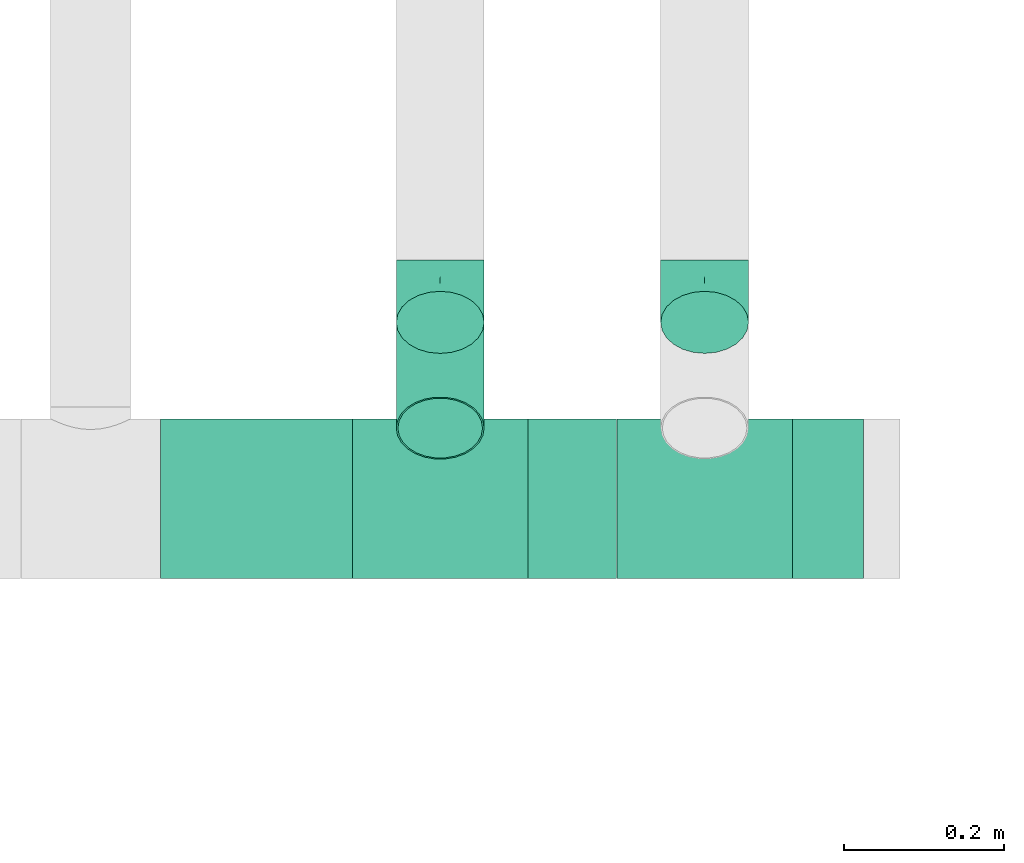
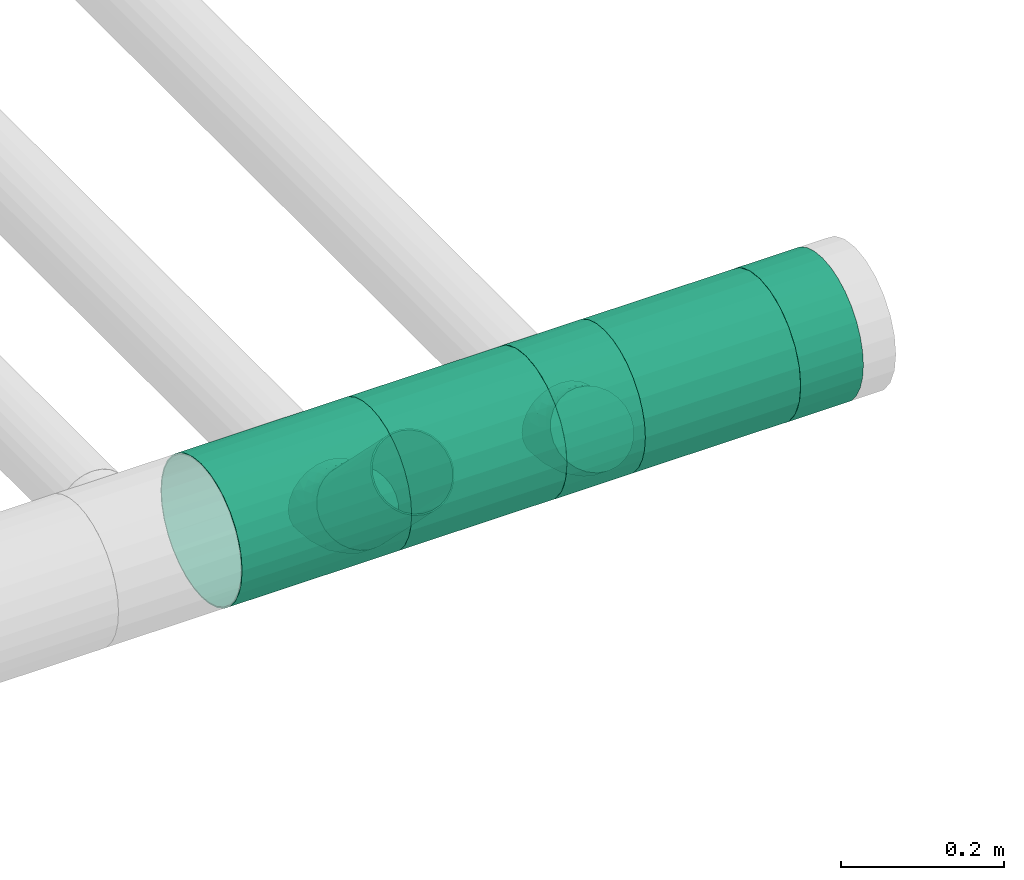
# One storey, part 86 of 91: 4 flow fittings, 4 flow segments.
"""IFC2X3 building model written with IfcOpenShell, lengths in millimetres."""

from ifc_helpers import new_model, entity, si_unit, converted_unit, derived_unit, direction, frame, origin_with_axes, origin_2d_with_axis, place, context, subcontext, project, spatial, hollow_circle, extrude, open_shell, surface_model, source, transform, mapped, material, layer, layer_set, layer_usage, type_object, element, save


model = new_model("IFC2X3")

# Units and contexts
model_context = context("Model", 3, precision=1e-05, world=origin_with_axes(), true_north=direction((0.0, 1.0)))
body_context = subcontext(model_context, "Body", "Model", "MODEL_VIEW")
ifc_project = project(units=[si_unit("AREAUNIT", "SQUARE_METRE"), si_unit("VOLUMEUNIT", "CUBIC_METRE", prefix="DECI"), si_unit("TIMEUNIT", "SECOND"), si_unit("THERMODYNAMICTEMPERATUREUNIT", "DEGREE_CELSIUS"), si_unit("PRESSUREUNIT", "PASCAL"), si_unit("MASSUNIT", "GRAM", prefix="KILO"), si_unit("LENGTHUNIT", "METRE", prefix="MILLI"), si_unit("POWERUNIT", "WATT"), si_unit("ELECTRICCURRENTUNIT", "AMPERE"), si_unit("ELECTRICVOLTAGEUNIT", "VOLT"), derived_unit("VOLUMETRICFLOWRATEUNIT", [(si_unit("VOLUMEUNIT", "CUBIC_METRE", prefix="DECI"), 1), (si_unit("TIMEUNIT", "SECOND"), -1)]), derived_unit("LINEARVELOCITYUNIT", [(si_unit("LENGTHUNIT", "METRE"), 1), (si_unit("TIMEUNIT", "SECOND"), -1)]), derived_unit("MASSDENSITYUNIT", [(si_unit("MASSUNIT", "GRAM", prefix="KILO"), 1), (si_unit("VOLUMEUNIT", "CUBIC_METRE"), -1)]), converted_unit("PLANEANGLEUNIT", "DEGREE", entity("IfcRatioMeasure", 0.01745), si_unit("PLANEANGLEUNIT", "RADIAN"), dimensions=[0, 0, 0, 0, 0, 0, 0])], contexts=[model_context])

# Site, building, storey
site_placement = place(None, origin_with_axes())
site = spatial("IfcSite", under=ifc_project, at=site_placement, CompositionType="ELEMENT")
building_placement = place(site_placement, origin_with_axes())
building = spatial("IfcBuilding", under=site, at=building_placement, Name="mc-building", CompositionType="ELEMENT")
storey_placement = place(building_placement, frame((0.0, 0.0, 8700.0), z_axis=(0.0, 0.0, 1.0), x_axis=(1.0, 0.0, 0.0)))
storey = spatial("IfcBuildingStorey", under=building, at=storey_placement, CompositionType="ELEMENT", Elevation=8700.0)

# Flow fittings
duct_fitting_type_1 = type_object("IfcDuctFittingType", Name="BU", PredefinedType="BEND")
shared_shape_1 = source(origin_with_axes(), body_context, "Body", "SurfaceModel", [
    surface_model("IfcShellBasedSurfaceModel", [(-45.56349, 0.0, -55.0), (-45.56349, -14.23505, -53.12592), (-45.56349, 14.23505, -53.12592), (-45.56349, 53.12592, 14.23505), (-45.56349, 27.5, -47.63139), (-45.56349, 38.89087, -38.89087), (-45.56349, 47.63139, -27.5), (-45.56349, -55.0, 0.0), (-45.56349, -53.12592, 14.23505), (-45.56349, -38.89087, -38.89087), (-45.56349, -27.5, -47.63139), (-45.56349, -53.12592, -14.23505), (-45.56349, -47.63139, -27.5), (-45.56349, 53.12592, -14.23505), (-45.56349, 47.63139, 27.5), (-45.56349, 38.89087, 38.89087), (-45.56349, -14.23505, 53.12592), (-45.56349, 27.5, 47.63139), (-45.56349, 14.23505, 53.12592), (-45.56349, -47.63139, 27.5), (-45.56349, -38.89087, 38.89087), (-45.56349, -27.5, 47.63139), (-45.56349, 0.0, 55.0), (-45.56349, 55.0, 0.0), (22.15256, 42.28395, -53.12592), (-6.67262, 71.10913, 0.0), (32.21826, 32.21826, -55.0), (12.77282, 51.66369, -47.63139), (-1.46223, 65.89874, -27.5), (4.71825, 59.71825, -38.89087), (59.71825, 4.71825, -38.89087), (69.78395, -5.34744, 14.23505), (51.66369, 12.77282, -47.63139), (42.28395, 22.15256, -53.12592), (65.89874, -1.46223, -27.5), (69.78395, -5.34744, -14.23505), (71.10913, -6.67262, 0.0), (-5.34744, 69.78395, -14.23505), (-5.34744, 69.78395, 14.23505), (-1.46223, 65.89874, 27.5), (4.71825, 59.71825, 38.89087), (32.21826, 32.21826, 55.0), (12.77282, 51.66369, 47.63139), (22.15256, 42.28395, 53.12592), (59.71825, 4.71825, 38.89087), (65.89874, -1.46223, 27.5), (42.28395, 22.15256, 53.12592), (51.66369, 12.77282, 47.63139), (-20.16649, 48.68621, 33.48188), (-26.97111, 35.77503, 43.63444), (-7.30443, 43.73336, 43.63444), (-17.0934, 3.74816, 55.0), (-18.00408, 15.44793, 53.78143), (-30.11707, 22.39897, 50.81337), (-7.49776, 55.63651, 33.48188), (-15.97018, 58.74288, 21.04759), (-31.18231, 52.58712, 21.04759), (-18.35174, 61.03934, 10.51509), (-28.67677, 56.60048, 10.47121), (-34.03924, 44.64267, 33.48188), (-11.52288, 27.81868, 50.81338), (1.19951, 23.16465, 53.81115), (-33.77926, 57.34403, 0.0), (5.4586, 37.12132, 50.81809), (-24.5159, 59.18663, 0.0), (-16.66281, 64.4339, 0.0), (9.43651, 14.73721, 55.0), (-6.22531, 44.36822, -43.63444), (5.4586, 37.12132, -50.81809), (-34.03924, 44.64267, -33.48188), (9.43651, 14.73721, -55.0), (-17.0934, 3.74816, -55.0), (1.19951, 23.16465, -53.81115), (-11.52288, 27.81868, -50.81338), (-30.11707, 22.39897, -50.81337), (-25.75914, 36.08917, -43.63444), (-30.24487, 52.83011, -21.04759), (-20.16649, 48.68621, -33.48188), (-7.49776, 55.63651, -33.48188), (-18.00408, 15.44793, -53.78143), (-28.68366, 56.62226, -10.35271), (-14.15883, 63.53074, -10.87592), (-15.13548, 59.23394, -21.04759), (3.19797, -7.72059, -52.16847), (3.1272, -18.04126, -47.9241), (13.63233, -32.91136, -32.06475), (45.23618, -22.99734, -20.4997), (16.67434, -40.25541, -15.9539), (-17.3935, -51.68264, -9.80849), (-2.85835, -49.37776, 0.0), (48.84421, -24.24609, -9.80849), (-16.38424, -42.76862, -30.85433), (-6.97383, -29.41689, -42.70541), (41.82739, -18.65658, -30.85433), (-15.72523, -48.24839, -20.4997), (29.28945, -13.63928, -42.80781), (26.81493, -3.56603, -49.15704), (36.93651, -32.89419, 0.0), (-15.72523, -48.24839, 20.4997), (-17.3935, -51.68264, 9.80849), (-16.38424, -42.76862, 30.85433), (16.67434, -40.25541, 15.9539), (3.19797, -7.72059, 52.16847), (10.54583, -14.96836, 47.9241), (13.63233, -32.91136, 32.06475), (45.23618, -22.99734, 20.4997), (41.82739, -18.65658, 30.85433), (-11.06635, -30.3552, 42.80781), (25.73213, -15.86964, 42.70541), (-16.43945, -21.48258, 49.15704), (48.84421, -24.24609, 9.80849)], [open_shell([[[0, 1, 2]], [[2, 3, 4]], [[5, 3, 6]], [[4, 3, 5]], [[2, 7, 8]], [[9, 7, 10]], [[1, 10, 7]], [[11, 7, 12]], [[9, 12, 7]], [[7, 2, 1]], [[13, 6, 3]], [[14, 3, 2]], [[15, 14, 2]], [[16, 17, 2]], [[2, 17, 15]], [[16, 18, 17]], [[19, 20, 2]], [[19, 2, 8]], [[20, 21, 2]], [[2, 21, 16]], [[16, 22, 18]], [[23, 13, 3]], [[24, 25, 26]], [[27, 25, 24]], [[28, 25, 29]], [[29, 25, 27]], [[30, 26, 31]], [[26, 30, 32]], [[32, 33, 26]], [[34, 31, 35]], [[31, 34, 30]], [[35, 31, 36]], [[37, 25, 28]], [[26, 38, 39]], [[26, 39, 40]], [[41, 40, 42]], [[26, 40, 41]], [[42, 43, 41]], [[26, 44, 45]], [[31, 26, 45]], [[46, 47, 26]], [[47, 44, 26]], [[46, 26, 41]], [[26, 25, 38]], [[48, 49, 50]], [[22, 51, 52]], [[17, 49, 15]], [[53, 17, 18]], [[49, 17, 53]], [[54, 50, 40]], [[48, 55, 56]], [[55, 57, 58]], [[59, 14, 15]], [[60, 53, 52]], [[50, 49, 60]], [[58, 3, 56]], [[52, 51, 61]], [[62, 23, 3]], [[63, 50, 60]], [[50, 42, 40]], [[3, 58, 62]], [[43, 61, 41]], [[62, 58, 64]], [[48, 59, 49]], [[14, 56, 3]], [[40, 39, 54]], [[57, 64, 58]], [[39, 38, 55]], [[63, 60, 61]], [[54, 55, 48]], [[65, 57, 38]], [[56, 14, 59]], [[38, 25, 65]], [[60, 52, 61]], [[49, 59, 15]], [[55, 58, 56]], [[56, 59, 48]], [[55, 54, 39]], [[50, 54, 48]], [[18, 22, 52]], [[49, 53, 60]], [[18, 52, 53]], [[61, 51, 66]], [[41, 61, 66]], [[63, 61, 43]], [[43, 42, 63]], [[50, 63, 42]], [[38, 57, 55]], [[64, 57, 65]], [[67, 27, 68]], [[69, 5, 6]], [[70, 71, 72]], [[73, 74, 75]], [[76, 77, 69]], [[29, 78, 28]], [[2, 79, 0]], [[13, 23, 62]], [[2, 74, 79]], [[5, 75, 4]], [[77, 78, 67]], [[13, 62, 80]], [[64, 80, 62]], [[81, 80, 64]], [[67, 73, 75]], [[82, 77, 76]], [[81, 64, 65]], [[76, 69, 6]], [[82, 76, 80]], [[24, 72, 68]], [[74, 2, 4]], [[27, 67, 29]], [[26, 70, 72]], [[69, 75, 5]], [[82, 28, 78]], [[72, 71, 79]], [[6, 13, 76]], [[77, 67, 75]], [[13, 80, 76]], [[82, 37, 28]], [[81, 25, 37]], [[82, 81, 37]], [[75, 69, 77]], [[67, 78, 29]], [[82, 78, 77]], [[75, 74, 4]], [[79, 74, 73]], [[79, 73, 72]], [[79, 71, 0]], [[68, 72, 73]], [[26, 72, 24]], [[67, 68, 73]], [[27, 24, 68]], [[80, 81, 82]], [[25, 81, 65]], [[1, 83, 84]], [[85, 86, 87]], [[0, 71, 1]], [[88, 87, 89]], [[90, 86, 35]], [[91, 92, 85]], [[11, 88, 7]], [[30, 34, 93]], [[11, 12, 94]], [[92, 91, 9]], [[85, 94, 91]], [[94, 85, 87]], [[95, 93, 85]], [[85, 92, 95]], [[83, 71, 70]], [[12, 9, 91]], [[70, 26, 33]], [[96, 84, 83]], [[1, 71, 83]], [[95, 96, 32]], [[95, 30, 93]], [[95, 32, 30]], [[97, 89, 87]], [[34, 86, 93]], [[36, 97, 90]], [[94, 88, 11]], [[34, 35, 86]], [[90, 87, 86]], [[93, 86, 85]], [[32, 96, 33]], [[84, 10, 1]], [[33, 83, 70]], [[94, 12, 91]], [[10, 92, 9]], [[87, 88, 94]], [[7, 88, 89]], [[36, 90, 35]], [[87, 90, 97]], [[84, 95, 92]], [[33, 96, 83]], [[95, 84, 96]], [[10, 84, 92]], [[8, 98, 19]], [[7, 89, 99]], [[19, 98, 100]], [[101, 98, 99]], [[46, 102, 103]], [[104, 105, 106]], [[100, 98, 104]], [[107, 104, 108]], [[16, 51, 22]], [[51, 16, 102]], [[107, 20, 100]], [[107, 109, 21]], [[21, 20, 107]], [[103, 47, 46]], [[101, 89, 97]], [[105, 110, 31]], [[44, 47, 108]], [[105, 104, 101]], [[107, 100, 104]], [[31, 110, 36]], [[109, 16, 21]], [[108, 106, 44]], [[105, 45, 106]], [[41, 66, 46]], [[102, 66, 51]], [[46, 66, 102]], [[104, 98, 101]], [[99, 98, 8]], [[106, 108, 104]], [[110, 101, 97]], [[45, 44, 106]], [[105, 31, 45]], [[20, 19, 100]], [[109, 103, 102]], [[101, 110, 105]], [[36, 110, 97]], [[7, 99, 8]], [[101, 99, 89]], [[103, 107, 108]], [[16, 109, 102]], [[107, 103, 109]], [[47, 103, 108]]])]),
])
for number, where, z_axis, x_axis, name in (
    (1, (36722.77222, 10333.96985, 415.0), (-1.0, 0.0, 0.0), (0.0, -1.0, 0.0), "BU"),
    (2, (36391.76813, 10333.96985, 415.0), (-1.0, 0.0, 0.0), (0.0, -1.0, 0.0), "BU"),
):
    element("IfcFlowFitting", number, at=place(storey_placement, frame(where, z_axis=z_axis, x_axis=x_axis)), inside=storey, type_object=duct_fitting_type_1, Name=name, context=body_context, shape_type="MappedRepresentation", body=[
        mapped(shared_shape_1, transform((0.0, 0.0, 0.0), scale=1.0)),
    ])

# Flow segments
ifc_material = material(Name="FZ1")
ifc_layer = layer(ifc_material, 0.0)
ifc_layer_set = layer_set([ifc_layer], Name="FZ1")
ifc_layer_usage = layer_usage(ifc_layer_set, "AXIS1", "POSITIVE", 0.0)
duct_segment_type_1 = type_object("IfcDuctSegmentType", PredefinedType="RIGIDSEGMENT")
shared_shape_2 = source(origin_with_axes(), body_context, "Body", "SweptSolid", [
    extrude(hollow_circle(Radius=55.0, WallThickness=2.0, at=origin_2d_with_axis()), frame((0.0, 0.0, 0.0), z_axis=(1.0, 0.0, 0.0), x_axis=(0.0, 1.0, 0.0)), (0.0, 0.0, 1.0), 187.2),
])
flow_segment_1_placement = place(storey_placement, frame((36391.76813, 10169.3582, 579.61165), z_axis=(0.0, -0.707107, -0.707107), x_axis=(0.0, 0.707107, -0.707107)))
element("IfcFlowSegment", 3, at=flow_segment_1_placement, inside=storey, type_object=duct_segment_type_1, material=ifc_layer_usage, context=body_context, shape_type="MappedRepresentation", body=[
    mapped(shared_shape_2, transform((0.0, 0.0, 0.0), scale=1.0)),
])
duct_segment_type_2 = type_object("IfcDuctSegmentType", Name="Safe", PredefinedType="RIGIDSEGMENT")
shared_shape_3 = source(origin_with_axes(), body_context, "Body", "SweptSolid", [
    extrude(hollow_circle(Radius=100.0, WallThickness=2.0, at=origin_2d_with_axis()), frame((0.0, 0.0, 0.0), z_axis=(1.0, 0.0, 0.0), x_axis=(0.0, 1.0, 0.0)), (0.0, 0.0, 1.0), 88.8),
])
flow_segment_2_placement = place(storey_placement, frame((36832.77222, 10080.96985, 668.0), z_axis=(0.0, 0.0, 1.0), x_axis=(1.0, 0.0, 0.0)))
element("IfcFlowSegment", 4, at=flow_segment_2_placement, inside=storey, type_object=duct_segment_type_2, material=ifc_layer_usage, Name="Safe", context=body_context, shape_type="MappedRepresentation", body=[
    mapped(shared_shape_3, transform((0.0, 0.0, 0.0), scale=1.0)),
])

# Flow fittings
duct_fitting_type_2 = type_object("IfcDuctFittingType", PredefinedType="JUNCTION")
shared_shape_4 = source(origin_with_axes(), body_context, "Body", "SurfaceModel", [
    surface_model("IfcShellBasedSurfaceModel", [(0.0, -125.0, -55.0), (14.23505, -125.0, -53.12592), (-14.23505, -125.0, -53.12592), (-53.12592, -125.0, 14.23505), (-27.5, -125.0, -47.63139), (-47.63139, -125.0, -27.5), (-38.89087, -125.0, -38.89087), (55.0, -125.0, 0.0), (53.12592, -125.0, 14.23505), (38.89087, -125.0, -38.89087), (27.5, -125.0, -47.63139), (53.12592, -125.0, -14.23505), (47.63139, -125.0, -27.5), (-53.12592, -125.0, -14.23505), (-47.63139, -125.0, 27.5), (-38.89087, -125.0, 38.89087), (14.23505, -125.0, 53.12592), (-27.5, -125.0, 47.63139), (-14.23505, -125.0, 53.12592), (47.63139, -125.0, 27.5), (38.89087, -125.0, 38.89087), (27.5, -125.0, 47.63139), (0.0, -125.0, 55.0), (-55.0, -125.0, 0.0), (0.0, -83.51647, 55.0), (-12.46155, -84.44105, 53.56967), (-24.08744, -86.92068, 49.44487), (-34.33571, -90.29918, 42.96579), (-42.88021, -93.88137, 34.44253), (-49.41352, -97.03966, 24.15169), (-53.56772, -99.21945, 12.46996), (-55.0, -100.0, 0.0), (-49.4132, -97.0395, -24.15234), (-42.88214, -93.88226, -34.44012), (-53.56653, -99.21882, -12.47503), (-34.33656, -90.29949, -42.96511), (-24.08533, -86.92009, -49.4459), (-12.45457, -84.44001, -53.57129), (0.0, -83.51647, -55.0), (12.46155, -84.44105, -53.56967), (24.08744, -86.92068, -49.44487), (34.33571, -90.29918, -42.96579), (42.88021, -93.88137, -34.44253), (49.41352, -97.03966, -24.15169), (53.56772, -99.21945, -12.46996), (55.0, -100.0, 0.0), (49.41352, -97.03966, 24.15169), (42.88021, -93.88137, 34.44253), (53.56772, -99.21945, 12.46996), (34.33571, -90.29918, 42.96579), (24.08744, -86.92068, 49.44487), (12.46155, -84.44105, 53.56967), (-110.0, 0.0, -100.0), (-110.0, -25.8819, -96.59259), (-110.0, 25.8819, -96.59259), (-110.0, 96.59259, 25.8819), (-110.0, 50.0, -86.60254), (-110.0, 86.60254, -50.0), (-110.0, 70.71068, -70.71068), (-110.0, -100.0, 0.0), (-110.0, -96.59259, 25.8819), (-110.0, -70.71068, -70.71068), (-110.0, -50.0, -86.60254), (-110.0, -96.59259, -25.8819), (-110.0, -86.60254, -50.0), (-110.0, 96.59259, -25.8819), (-110.0, 86.60254, 50.0), (-110.0, 70.71068, 70.71068), (-110.0, 50.0, 86.60254), (-110.0, 25.8819, 96.59259), (-110.0, 0.0, 100.0), (-110.0, -86.60254, 50.0), (-110.0, -70.71068, 70.71068), (-110.0, -25.8819, 96.59259), (-110.0, -50.0, 86.60254), (-110.0, 100.0, 0.0), (110.0, 25.8819, -96.59259), (110.0, 100.0, 0.0), (110.0, 0.0, -100.0), (110.0, 50.0, -86.60254), (110.0, 86.60254, -50.0), (110.0, 70.71068, -70.71068), (110.0, -70.71068, -70.71068), (110.0, -96.59259, 25.8819), (110.0, -50.0, -86.60254), (110.0, -25.8819, -96.59259), (110.0, -86.60254, -50.0), (110.0, -96.59259, -25.8819), (110.0, -100.0, 0.0), (110.0, 96.59259, -25.8819), (110.0, 86.60254, 50.0), (110.0, 96.59259, 25.8819), (110.0, 50.0, 86.60254), (110.0, 25.8819, 96.59259), (110.0, 70.71068, 70.71068), (110.0, -25.8819, 96.59259), (110.0, -86.60254, 50.0), (110.0, -70.71068, 70.71068), (110.0, -50.0, 86.60254), (110.0, 0.0, 100.0), (-110.0, -98.29629, -12.94095), (110.0, -91.59756, -37.94095), (-110.0, -91.59756, -37.94095), (110.0, -98.29629, -12.94095), (110.0, -98.29629, 12.94095), (110.0, -91.59756, 37.94095), (-110.0, -98.29629, 12.94095), (-110.0, -91.59756, 37.94095)], [open_shell([[[0, 1, 2]], [[2, 3, 4]], [[5, 6, 3]], [[6, 4, 3]], [[2, 7, 8]], [[9, 7, 10]], [[1, 10, 7]], [[11, 7, 12]], [[9, 12, 7]], [[7, 2, 1]], [[5, 3, 13]], [[2, 14, 3]], [[2, 15, 14]], [[2, 16, 17]], [[17, 15, 2]], [[16, 18, 17]], [[2, 8, 19]], [[2, 19, 20]], [[2, 20, 21]], [[16, 2, 21]], [[16, 22, 18]], [[23, 13, 3]], [[22, 24, 25]], [[18, 25, 26]], [[22, 25, 18]], [[17, 27, 15]], [[17, 18, 26]], [[27, 17, 26]], [[28, 29, 14]], [[30, 31, 23]], [[29, 30, 3]], [[15, 28, 14]], [[23, 3, 30]], [[29, 3, 14]], [[28, 15, 27]], [[32, 33, 5]], [[34, 32, 13]], [[31, 34, 23]], [[23, 34, 13]], [[32, 5, 13]], [[33, 6, 5]], [[4, 35, 36]], [[36, 37, 2]], [[38, 0, 37]], [[6, 35, 4]], [[4, 36, 2]], [[37, 0, 2]], [[35, 6, 33]], [[0, 38, 39]], [[1, 39, 40]], [[0, 39, 1]], [[10, 41, 9]], [[10, 1, 40]], [[41, 10, 40]], [[42, 43, 12]], [[44, 45, 7]], [[43, 44, 11]], [[12, 9, 42]], [[11, 12, 43]], [[44, 7, 11]], [[42, 9, 41]], [[46, 47, 19]], [[48, 46, 8]], [[45, 48, 7]], [[7, 48, 8]], [[46, 19, 8]], [[47, 20, 19]], [[21, 49, 50]], [[50, 51, 16]], [[24, 22, 51]], [[21, 20, 49]], [[16, 21, 50]], [[51, 22, 16]], [[49, 20, 47]], [[52, 53, 54]], [[54, 55, 56]], [[57, 58, 55]], [[58, 56, 55]], [[54, 59, 60]], [[61, 59, 62]], [[54, 53, 62]], [[63, 59, 64]], [[61, 64, 59]], [[62, 59, 54]], [[57, 55, 65]], [[66, 55, 54]], [[54, 67, 66]], [[68, 54, 69]], [[68, 67, 54]], [[70, 69, 54]], [[71, 72, 54]], [[54, 60, 71]], [[73, 70, 74]], [[54, 72, 74]], [[74, 70, 54]], [[75, 65, 55]], [[76, 77, 78]], [[79, 77, 76]], [[80, 77, 81]], [[79, 81, 77]], [[82, 78, 83]], [[78, 84, 85]], [[78, 82, 84]], [[86, 83, 87]], [[83, 86, 82]], [[88, 87, 83]], [[77, 80, 89]], [[90, 78, 91]], [[78, 90, 92]], [[93, 78, 92]], [[92, 90, 94]], [[95, 78, 93]], [[78, 96, 83]], [[97, 96, 78]], [[97, 78, 98]], [[95, 98, 78]], [[93, 99, 95]], [[91, 78, 77]], [[69, 99, 93]], [[68, 93, 92]], [[70, 99, 69]], [[69, 93, 68]], [[92, 67, 68]], [[92, 94, 67]], [[55, 90, 91]], [[75, 91, 77]], [[94, 66, 67]], [[94, 90, 66]], [[66, 90, 55]], [[91, 75, 55]], [[89, 80, 57]], [[77, 89, 65]], [[65, 75, 77]], [[57, 65, 89]], [[80, 58, 57]], [[80, 81, 58]], [[54, 79, 76]], [[52, 76, 78]], [[81, 56, 58]], [[81, 79, 56]], [[56, 79, 54]], [[76, 52, 54]], [[85, 53, 78]], [[84, 62, 85]], [[82, 86, 39]], [[34, 59, 100]], [[39, 38, 82]], [[41, 101, 42]], [[84, 82, 61]], [[82, 38, 61]], [[85, 62, 53]], [[53, 52, 78]], [[37, 36, 64]], [[33, 63, 102]], [[64, 61, 37]], [[36, 35, 64]], [[61, 62, 84]], [[61, 38, 37]], [[39, 86, 40]], [[101, 41, 86]], [[41, 40, 86]], [[42, 87, 43]], [[88, 45, 44]], [[87, 103, 43]], [[44, 103, 88]], [[43, 103, 44]], [[64, 35, 102]], [[63, 33, 32]], [[102, 35, 33]], [[100, 63, 32]], [[31, 59, 34]], [[100, 32, 34]], [[101, 87, 42]], [[45, 88, 48]], [[104, 83, 46]], [[46, 83, 47]], [[46, 48, 104]], [[49, 47, 105]], [[105, 96, 49]], [[31, 30, 59]], [[59, 30, 106]], [[60, 28, 107]], [[60, 106, 29]], [[60, 29, 28]], [[27, 71, 107]], [[50, 96, 51]], [[96, 50, 49]], [[51, 96, 97]], [[29, 106, 30]], [[98, 95, 73]], [[74, 97, 98]], [[51, 97, 24]], [[70, 95, 99]], [[71, 25, 72]], [[48, 88, 104]], [[26, 71, 27]], [[71, 26, 25]], [[25, 24, 72]], [[27, 107, 28]], [[24, 97, 72]], [[97, 74, 72]], [[73, 74, 98]], [[95, 70, 73]], [[47, 83, 105]]])]),
])
for number, where, z_axis, x_axis in (
    (5, (36722.77222, 10080.96985, 668.0), (0.0, 0.707107, 0.707107), (-1.0, 0.0, 0.0)),
    (6, (36391.76813, 10080.96985, 668.0), (0.0, 0.707107, 0.707107), (-1.0, 0.0, 0.0)),
):
    element("IfcFlowFitting", number, at=place(storey_placement, frame(where, z_axis=z_axis, x_axis=x_axis)), inside=storey, type_object=duct_fitting_type_2, context=body_context, shape_type="MappedRepresentation", body=[
        mapped(shared_shape_4, transform((0.0, 0.0, 0.0), scale=1.0)),
    ])

# Flow segments
shared_shape_5 = source(origin_with_axes(), body_context, "Body", "SweptSolid", [
    extrude(hollow_circle(Radius=100.0, WallThickness=2.0, at=origin_2d_with_axis()), frame((0.0, 0.0, 0.0), z_axis=(1.0, 0.0, 0.0), x_axis=(0.0, 1.0, 0.0)), (0.0, 0.0, 1.0), 111.0),
])
flow_segment_3_placement = place(storey_placement, frame((36501.76813, 10080.96985, 668.0), z_axis=(0.0, 0.0, 1.0), x_axis=(1.0, 0.0, 0.0)))
element("IfcFlowSegment", 7, at=flow_segment_3_placement, inside=storey, type_object=duct_segment_type_2, material=ifc_layer_usage, Name="Safe", context=body_context, shape_type="MappedRepresentation", body=[
    mapped(shared_shape_5, transform((0.0, 0.0, 0.0), scale=1.0)),
])
shared_shape_6 = source(origin_with_axes(), body_context, "Body", "SweptSolid", [
    extrude(hollow_circle(Radius=100.0, WallThickness=2.0, at=origin_2d_with_axis()), frame((0.0, 0.0, 0.0), z_axis=(1.0, 0.0, 0.0), x_axis=(0.0, 1.0, 0.0)), (0.0, 0.0, 1.0), 240.1),
])
flow_segment_4_placement = place(storey_placement, frame((36041.71103, 10080.96985, 668.0), z_axis=(0.0, 0.0, 1.0), x_axis=(1.0, 0.0, 0.0)))
element("IfcFlowSegment", 8, at=flow_segment_4_placement, inside=storey, type_object=duct_segment_type_2, material=ifc_layer_usage, Name="Safe", context=body_context, shape_type="MappedRepresentation", body=[
    mapped(shared_shape_6, transform((0.0, 0.0, 0.0), scale=1.0)),
])

save(model, "model.ifc")
